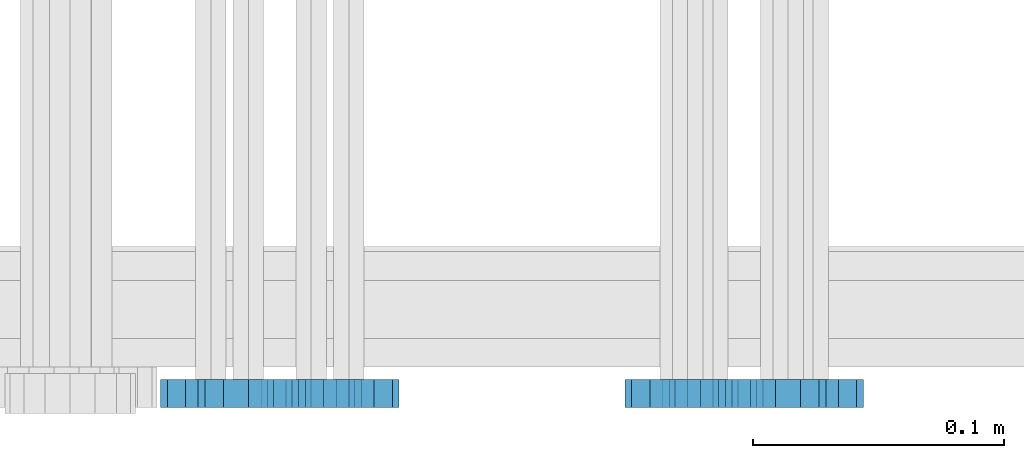
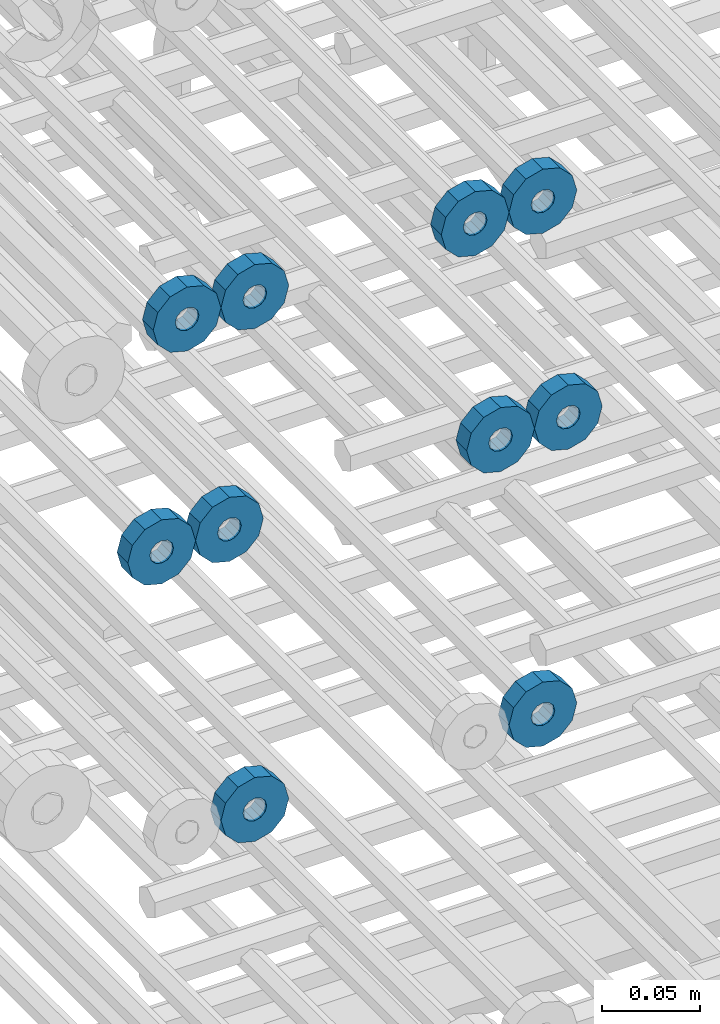
# One storey, part 159 of 177: 10 beams.
"""IFC2X3 building model written with IfcOpenShell, lengths in millimetres."""

from ifc_helpers import new_model, si_unit, frame, origin_with_axes, place, context, subcontext, project, spatial, faceted_brep, material, type_object, element, save


model = new_model("IFC2X3")

# Units and contexts
model_context_1 = context("Model", 3, precision=1e-05, world=origin_with_axes())
model_context_2 = context("Model", 3, precision=1e-05, world=origin_with_axes())
body_context = subcontext(model_context_2, "Body", "Model", "MODEL_VIEW")
ifc_project = project(units=[si_unit("LENGTHUNIT", "METRE", prefix="MILLI"), si_unit("AREAUNIT", "SQUARE_METRE"), si_unit("VOLUMEUNIT", "CUBIC_METRE"), si_unit("MASSUNIT", "GRAM", prefix="KILO"), si_unit("TIMEUNIT", "SECOND"), si_unit("PLANEANGLEUNIT", "RADIAN"), si_unit("SOLIDANGLEUNIT", "STERADIAN"), si_unit("THERMODYNAMICTEMPERATUREUNIT", "DEGREE_CELSIUS"), si_unit("LUMINOUSINTENSITYUNIT", "LUMEN")], contexts=[model_context_1])

# Site, building, storey
site_placement = place(None, origin_with_axes())
site = spatial("IfcSite", under=ifc_project, at=site_placement, CompositionType="ELEMENT")
building_placement = place(site_placement, origin_with_axes())
building = spatial("IfcBuilding", under=site, at=building_placement, Name="Undefined", CompositionType="ELEMENT")
storey_placement = place(building_placement, origin_with_axes())
storey = spatial("IfcBuildingStorey", under=building, at=storey_placement, Name="Undefined", CompositionType="ELEMENT", Elevation=0.0)

# Beams
ifc_material = material(Name="STEEL/Steel_Undefined")
beam_type = type_object("IfcBeamType", PredefinedType="NOTDEFINED")
beam_1_placement = place(storey_placement, frame((2035816.99847313, 6205070.98588033, 21144.9868114202), z_axis=(0.0, 0.0, -1.0), x_axis=(0.0, -1.0, 0.0)))
element("IfcBeam", 1, at=beam_1_placement, inside=storey, type_object=beam_type, material=ifc_material, context=body_context, shape_type="Brep", body=[
    faceted_brep([(-3.63797880709171e-12, -7.0, -2.3283064365387e-10), (-8.62348444298797e-13, -6.06217782649107, 3.5), (10.9999999999964, -6.06217782665044, 3.49999999976717), (10.9999999999964, -7.0, -2.3283064365387e-10), (-3.63797880709171e-12, -3.5, 6.06217782618478), (11.0, -3.5, 6.06217782618478), (-1.72469688859759e-12, 0.0, 7.0), (11.0, 0.0, 6.99999999976717), (-3.63797880709171e-12, 3.5, 6.06217782618478), (11.0, 3.5, 6.06217782618478), (-8.62348444298795e-13, 6.06217782649107, 3.5), (10.9999999999964, 6.06217782665044, 3.49999999976717), (-3.63797880709171e-12, 7.0, -2.3283064365387e-10), (10.9999999999964, 7.0, -2.3283064365387e-10), (8.62348444298797e-13, 6.06217782649107, -3.5), (10.9999999999964, 6.06217782665044, -3.50000000023283), (-3.63797880709171e-12, 3.5, -6.06217782665044), (10.9999999999964, 3.5, -6.06217782665044), (1.72469688859759e-12, -2.72004641033163e-15, -7.0), (10.9999999999964, 0.0, -7.00000000023283), (-3.63797880709171e-12, -3.5, -6.06217782665044), (10.9999999999964, -3.5, -6.06217782665044), (8.62348444298796e-13, -6.06217782649107, -3.5), (10.9999999999964, -6.06217782665044, -3.50000000023283), (0.0, -20.0000000009313, 0.0), (0.0, -17.320508075878, -10.0), (10.9999999999964, -17.320508075878, -10.0000000002328), (10.9999999999964, -20.0, -2.3283064365387e-10), (0.0, -10.0000000009313, -17.3205080756452), (11.0, -10.0, -17.320508075878), (0.0, -1.86264514923096e-09, -19.9999999998836), (10.9999999999964, 0.0, -20.0000000002328), (0.0, 9.99999999906868, -17.3205080755288), (11.0, 10.0, -17.320508075878), (0.0, 17.320508075878, -10.0), (10.9999999999964, 17.320508075878, -10.0000000002328), (0.0, 19.9999999990687, 0.0), (10.9999999999964, 20.0, -2.3283064365387e-10), (0.0, 17.3205080740154, 10.0), (11.0, 17.320508075878, 9.99999999976717), (0.0, 9.99999999906868, 17.3205080757616), (10.9999999999964, 10.0, 17.3205080754124), (0.0, 0.0, 20.0000000001164), (10.9999999999964, 0.0, 19.9999999997672), (0.0, -10.0000000009313, 17.3205080757616), (10.9999999999964, -10.0, 17.3205080754124), (0.0, -17.3205080777407, 10.0000000001164), (11.0, -17.320508075878, 9.99999999976717)], [[[0, 1, 2, 3]], [[1, 4, 5, 2]], [[4, 6, 7, 5]], [[6, 8, 9, 7]], [[8, 10, 11, 9]], [[10, 12, 13, 11]], [[12, 14, 15, 13]], [[14, 16, 17, 15]], [[16, 18, 19, 17]], [[18, 20, 21, 19]], [[20, 22, 23, 21]], [[22, 0, 3, 23]], [[24, 25, 26, 27]], [[25, 28, 29, 26]], [[28, 30, 31, 29]], [[30, 32, 33, 31]], [[32, 34, 35, 33]], [[34, 36, 37, 35]], [[36, 38, 39, 37]], [[38, 40, 41, 39]], [[40, 42, 43, 41]], [[42, 44, 45, 43]], [[44, 46, 47, 45]], [[46, 24, 27, 47]], [[29, 31, 33, 35, 37, 39, 41, 43, 45, 47, 27, 26], [5, 7, 9, 11, 13, 15, 17, 19, 21, 23, 3, 2]], [[46, 44, 42, 40, 38, 36, 34, 32, 30, 28, 25, 24], [22, 20, 18, 16, 14, 12, 10, 8, 6, 4, 1, 0]]]),
])
beam_2_placement = place(storey_placement, frame((2035646.99847313, 6205070.98588033, 21144.9868114254), z_axis=(0.0, 0.0, -1.0), x_axis=(0.0, -1.0, 0.0)))
element("IfcBeam", 2, at=beam_2_placement, inside=storey, type_object=beam_type, material=ifc_material, context=body_context, shape_type="Brep", body=[
    faceted_brep([(-3.63797880709171e-12, -7.0, -2.3283064365387e-10), (-8.62348444298797e-13, -6.06217782649107, 3.5), (10.9999999999964, -6.06217782665044, 3.49999999976717), (10.9999999999964, -7.0, -2.3283064365387e-10), (-3.63797880709171e-12, -3.5, 6.06217782618478), (11.0, -3.5, 6.06217782618478), (-1.72469688859759e-12, 0.0, 7.0), (11.0, 0.0, 6.99999999976717), (-3.63797880709171e-12, 3.5, 6.06217782618478), (11.0, 3.5, 6.06217782618478), (-8.62348444298795e-13, 6.06217782649107, 3.5), (10.9999999999964, 6.06217782665044, 3.49999999976717), (-3.63797880709171e-12, 7.0, -2.3283064365387e-10), (10.9999999999964, 7.0, -2.3283064365387e-10), (8.62348444298797e-13, 6.06217782649107, -3.5), (10.9999999999964, 6.06217782665044, -3.50000000023283), (-3.63797880709171e-12, 3.5, -6.06217782665044), (10.9999999999964, 3.5, -6.06217782665044), (1.72469688859759e-12, -2.72004641033163e-15, -7.0), (10.9999999999964, 0.0, -7.00000000023283), (-3.63797880709171e-12, -3.5, -6.06217782665044), (10.9999999999964, -3.5, -6.06217782665044), (8.62348444298796e-13, -6.06217782649107, -3.5), (10.9999999999964, -6.06217782665044, -3.50000000023283), (0.0, -20.0000000009313, 0.0), (0.0, -17.320508075878, -10.0), (10.9999999999964, -17.320508075878, -10.0000000002328), (10.9999999999964, -20.0, -2.3283064365387e-10), (0.0, -10.0000000009313, -17.3205080756452), (11.0, -10.0, -17.320508075878), (0.0, -1.86264514923096e-09, -19.9999999998836), (10.9999999999964, 0.0, -20.0000000002328), (0.0, 9.99999999906868, -17.3205080755288), (11.0, 10.0, -17.320508075878), (0.0, 17.320508075878, -10.0), (10.9999999999964, 17.320508075878, -10.0000000002328), (0.0, 19.9999999990687, 0.0), (10.9999999999964, 20.0, -2.3283064365387e-10), (0.0, 17.3205080740154, 10.0), (11.0, 17.320508075878, 9.99999999976717), (0.0, 9.99999999906868, 17.3205080757616), (10.9999999999964, 10.0, 17.3205080754124), (0.0, 0.0, 20.0000000001164), (10.9999999999964, 0.0, 19.9999999997672), (0.0, -10.0000000009313, 17.3205080757616), (10.9999999999964, -10.0, 17.3205080754124), (0.0, -17.3205080777407, 10.0000000001164), (11.0, -17.320508075878, 9.99999999976717)], [[[0, 1, 2, 3]], [[1, 4, 5, 2]], [[4, 6, 7, 5]], [[6, 8, 9, 7]], [[8, 10, 11, 9]], [[10, 12, 13, 11]], [[12, 14, 15, 13]], [[14, 16, 17, 15]], [[16, 18, 19, 17]], [[18, 20, 21, 19]], [[20, 22, 23, 21]], [[22, 0, 3, 23]], [[24, 25, 26, 27]], [[25, 28, 29, 26]], [[28, 30, 31, 29]], [[30, 32, 33, 31]], [[32, 34, 35, 33]], [[34, 36, 37, 35]], [[36, 38, 39, 37]], [[38, 40, 41, 39]], [[40, 42, 43, 41]], [[42, 44, 45, 43]], [[44, 46, 47, 45]], [[46, 24, 27, 47]], [[29, 31, 33, 35, 37, 39, 41, 43, 45, 47, 27, 26], [5, 7, 9, 11, 13, 15, 17, 19, 21, 23, 3, 2]], [[46, 44, 42, 40, 38, 36, 34, 32, 30, 28, 25, 24], [22, 20, 18, 16, 14, 12, 10, 8, 6, 4, 1, 0]]]),
])
beam_3_placement = place(storey_placement, frame((2035776.99847313, 6205070.98588033, 21144.9868114202), z_axis=(0.0, 0.0, -1.0), x_axis=(0.0, -1.0, 0.0)))
element("IfcBeam", 3, at=beam_3_placement, inside=storey, type_object=beam_type, material=ifc_material, context=body_context, shape_type="Brep", body=[
    faceted_brep([(-3.63797880709171e-12, -7.0, -2.3283064365387e-10), (-8.62348444298797e-13, -6.06217782649107, 3.5), (10.9999999999964, -6.06217782665044, 3.49999999976717), (10.9999999999964, -7.0, -2.3283064365387e-10), (-3.63797880709171e-12, -3.5, 6.06217782618478), (11.0, -3.5, 6.06217782618478), (-1.72469688859759e-12, 0.0, 7.0), (11.0, 0.0, 6.99999999976717), (-3.63797880709171e-12, 3.5, 6.06217782618478), (11.0, 3.5, 6.06217782618478), (-8.62348444298795e-13, 6.06217782649107, 3.5), (10.9999999999964, 6.06217782665044, 3.49999999976717), (-3.63797880709171e-12, 7.0, -2.3283064365387e-10), (10.9999999999964, 7.0, -2.3283064365387e-10), (8.62348444298797e-13, 6.06217782649107, -3.5), (10.9999999999964, 6.06217782665044, -3.50000000023283), (-3.63797880709171e-12, 3.5, -6.06217782665044), (10.9999999999964, 3.5, -6.06217782665044), (1.72469688859759e-12, -2.72004641033163e-15, -7.0), (10.9999999999964, 0.0, -7.00000000023283), (-3.63797880709171e-12, -3.5, -6.06217782665044), (10.9999999999964, -3.5, -6.06217782665044), (8.62348444298796e-13, -6.06217782649107, -3.5), (10.9999999999964, -6.06217782665044, -3.50000000023283), (0.0, -20.0000000009313, 0.0), (0.0, -17.320508075878, -10.0), (10.9999999999964, -17.320508075878, -10.0000000002328), (10.9999999999964, -20.0, -2.3283064365387e-10), (0.0, -10.0000000009313, -17.3205080756452), (11.0, -10.0, -17.320508075878), (0.0, -1.86264514923096e-09, -19.9999999998836), (10.9999999999964, 0.0, -20.0000000002328), (0.0, 9.99999999906868, -17.3205080755288), (11.0, 10.0, -17.320508075878), (0.0, 17.320508075878, -10.0), (10.9999999999964, 17.320508075878, -10.0000000002328), (0.0, 19.9999999990687, 0.0), (10.9999999999964, 20.0, -2.3283064365387e-10), (0.0, 17.3205080740154, 10.0), (11.0, 17.320508075878, 9.99999999976717), (0.0, 9.99999999906868, 17.3205080757616), (10.9999999999964, 10.0, 17.3205080754124), (0.0, 0.0, 20.0000000001164), (10.9999999999964, 0.0, 19.9999999997672), (0.0, -10.0000000009313, 17.3205080757616), (10.9999999999964, -10.0, 17.3205080754124), (0.0, -17.3205080777407, 10.0000000001164), (11.0, -17.320508075878, 9.99999999976717)], [[[0, 1, 2, 3]], [[1, 4, 5, 2]], [[4, 6, 7, 5]], [[6, 8, 9, 7]], [[8, 10, 11, 9]], [[10, 12, 13, 11]], [[12, 14, 15, 13]], [[14, 16, 17, 15]], [[16, 18, 19, 17]], [[18, 20, 21, 19]], [[20, 22, 23, 21]], [[22, 0, 3, 23]], [[24, 25, 26, 27]], [[25, 28, 29, 26]], [[28, 30, 31, 29]], [[30, 32, 33, 31]], [[32, 34, 35, 33]], [[34, 36, 37, 35]], [[36, 38, 39, 37]], [[38, 40, 41, 39]], [[40, 42, 43, 41]], [[42, 44, 45, 43]], [[44, 46, 47, 45]], [[46, 24, 27, 47]], [[29, 31, 33, 35, 37, 39, 41, 43, 45, 47, 27, 26], [5, 7, 9, 11, 13, 15, 17, 19, 21, 23, 3, 2]], [[46, 44, 42, 40, 38, 36, 34, 32, 30, 28, 25, 24], [22, 20, 18, 16, 14, 12, 10, 8, 6, 4, 1, 0]]]),
])
beam_4_placement = place(storey_placement, frame((2035606.99847313, 6205070.98588033, 21144.9868114254), z_axis=(0.0, 0.0, -1.0), x_axis=(0.0, -1.0, 0.0)))
element("IfcBeam", 4, at=beam_4_placement, inside=storey, type_object=beam_type, material=ifc_material, context=body_context, shape_type="Brep", body=[
    faceted_brep([(-3.63797880709171e-12, -7.0, -2.3283064365387e-10), (-8.62348444298797e-13, -6.06217782649107, 3.5), (10.9999999999964, -6.06217782665044, 3.49999999976717), (10.9999999999964, -7.0, -2.3283064365387e-10), (-3.63797880709171e-12, -3.5, 6.06217782618478), (11.0, -3.5, 6.06217782618478), (-1.72469688859759e-12, 0.0, 7.0), (11.0, 0.0, 6.99999999976717), (-3.63797880709171e-12, 3.5, 6.06217782618478), (11.0, 3.5, 6.06217782618478), (-8.62348444298795e-13, 6.06217782649107, 3.5), (10.9999999999964, 6.06217782665044, 3.49999999976717), (-3.63797880709171e-12, 7.0, -2.3283064365387e-10), (10.9999999999964, 7.0, -2.3283064365387e-10), (8.62348444298797e-13, 6.06217782649107, -3.5), (10.9999999999964, 6.06217782665044, -3.50000000023283), (-3.63797880709171e-12, 3.5, -6.06217782665044), (10.9999999999964, 3.5, -6.06217782665044), (1.72469688859759e-12, -2.72004641033163e-15, -7.0), (10.9999999999964, 0.0, -7.00000000023283), (-3.63797880709171e-12, -3.5, -6.06217782665044), (10.9999999999964, -3.5, -6.06217782665044), (8.62348444298796e-13, -6.06217782649107, -3.5), (10.9999999999964, -6.06217782665044, -3.50000000023283), (0.0, -20.0000000009313, 0.0), (0.0, -17.320508075878, -10.0), (10.9999999999964, -17.320508075878, -10.0000000002328), (10.9999999999964, -20.0, -2.3283064365387e-10), (0.0, -10.0000000009313, -17.3205080756452), (11.0, -10.0, -17.320508075878), (0.0, -1.86264514923096e-09, -19.9999999998836), (10.9999999999964, 0.0, -20.0000000002328), (0.0, 9.99999999906868, -17.3205080755288), (11.0, 10.0, -17.320508075878), (0.0, 17.320508075878, -10.0), (10.9999999999964, 17.320508075878, -10.0000000002328), (0.0, 19.9999999990687, 0.0), (10.9999999999964, 20.0, -2.3283064365387e-10), (0.0, 17.3205080740154, 10.0), (11.0, 17.320508075878, 9.99999999976717), (0.0, 9.99999999906868, 17.3205080757616), (10.9999999999964, 10.0, 17.3205080754124), (0.0, 0.0, 20.0000000001164), (10.9999999999964, 0.0, 19.9999999997672), (0.0, -10.0000000009313, 17.3205080757616), (10.9999999999964, -10.0, 17.3205080754124), (0.0, -17.3205080777407, 10.0000000001164), (11.0, -17.320508075878, 9.99999999976717)], [[[0, 1, 2, 3]], [[1, 4, 5, 2]], [[4, 6, 7, 5]], [[6, 8, 9, 7]], [[8, 10, 11, 9]], [[10, 12, 13, 11]], [[12, 14, 15, 13]], [[14, 16, 17, 15]], [[16, 18, 19, 17]], [[18, 20, 21, 19]], [[20, 22, 23, 21]], [[22, 0, 3, 23]], [[24, 25, 26, 27]], [[25, 28, 29, 26]], [[28, 30, 31, 29]], [[30, 32, 33, 31]], [[32, 34, 35, 33]], [[34, 36, 37, 35]], [[36, 38, 39, 37]], [[38, 40, 41, 39]], [[40, 42, 43, 41]], [[42, 44, 45, 43]], [[44, 46, 47, 45]], [[46, 24, 27, 47]], [[29, 31, 33, 35, 37, 39, 41, 43, 45, 47, 27, 26], [5, 7, 9, 11, 13, 15, 17, 19, 21, 23, 3, 2]], [[46, 44, 42, 40, 38, 36, 34, 32, 30, 28, 25, 24], [22, 20, 18, 16, 14, 12, 10, 8, 6, 4, 1, 0]]]),
])
beam_5_placement = place(storey_placement, frame((2035831.99847313, 6205070.98588033, 21004.9868114202), z_axis=(0.0, 0.0, -1.0), x_axis=(0.0, -1.0, 0.0)))
element("IfcBeam", 5, at=beam_5_placement, inside=storey, type_object=beam_type, material=ifc_material, context=body_context, shape_type="Brep", body=[
    faceted_brep([(-3.63797880709171e-12, -7.0, -2.3283064365387e-10), (-8.62348444298797e-13, -6.06217782649107, 3.5), (10.9999999999964, -6.06217782665044, 3.49999999976717), (10.9999999999964, -7.0, -2.3283064365387e-10), (-3.63797880709171e-12, -3.5, 6.06217782618478), (11.0, -3.5, 6.06217782618478), (-1.72469688859759e-12, 0.0, 7.0), (11.0, 0.0, 6.99999999976717), (-3.63797880709171e-12, 3.5, 6.06217782618478), (11.0, 3.5, 6.06217782618478), (-8.62348444298795e-13, 6.06217782649107, 3.5), (10.9999999999964, 6.06217782665044, 3.49999999976717), (-3.63797880709171e-12, 7.0, -2.3283064365387e-10), (10.9999999999964, 7.0, -2.3283064365387e-10), (8.62348444298797e-13, 6.06217782649107, -3.5), (10.9999999999964, 6.06217782665044, -3.50000000023283), (-3.63797880709171e-12, 3.5, -6.06217782665044), (10.9999999999964, 3.5, -6.06217782665044), (1.72469688859759e-12, -2.72004641033163e-15, -7.0), (10.9999999999964, 0.0, -7.00000000023283), (-3.63797880709171e-12, -3.5, -6.06217782665044), (10.9999999999964, -3.5, -6.06217782665044), (8.62348444298796e-13, -6.06217782649107, -3.5), (10.9999999999964, -6.06217782665044, -3.50000000023283), (0.0, -20.0000000009313, 0.0), (0.0, -17.320508075878, -10.0), (10.9999999999964, -17.320508075878, -10.0000000002328), (10.9999999999964, -20.0, -2.3283064365387e-10), (0.0, -10.0000000009313, -17.3205080756452), (11.0, -10.0, -17.320508075878), (0.0, -1.86264514923096e-09, -19.9999999998836), (10.9999999999964, 0.0, -20.0000000002328), (0.0, 9.99999999906868, -17.3205080755288), (11.0, 10.0, -17.320508075878), (0.0, 17.320508075878, -10.0), (10.9999999999964, 17.320508075878, -10.0000000002328), (0.0, 19.9999999990687, 0.0), (10.9999999999964, 20.0, -2.3283064365387e-10), (0.0, 17.3205080740154, 10.0), (11.0, 17.320508075878, 9.99999999976717), (0.0, 9.99999999906868, 17.3205080757616), (10.9999999999964, 10.0, 17.3205080754124), (0.0, 0.0, 20.0000000001164), (10.9999999999964, 0.0, 19.9999999997672), (0.0, -10.0000000009313, 17.3205080757616), (10.9999999999964, -10.0, 17.3205080754124), (0.0, -17.3205080777407, 10.0000000001164), (11.0, -17.320508075878, 9.99999999976717)], [[[0, 1, 2, 3]], [[1, 4, 5, 2]], [[4, 6, 7, 5]], [[6, 8, 9, 7]], [[8, 10, 11, 9]], [[10, 12, 13, 11]], [[12, 14, 15, 13]], [[14, 16, 17, 15]], [[16, 18, 19, 17]], [[18, 20, 21, 19]], [[20, 22, 23, 21]], [[22, 0, 3, 23]], [[24, 25, 26, 27]], [[25, 28, 29, 26]], [[28, 30, 31, 29]], [[30, 32, 33, 31]], [[32, 34, 35, 33]], [[34, 36, 37, 35]], [[36, 38, 39, 37]], [[38, 40, 41, 39]], [[40, 42, 43, 41]], [[42, 44, 45, 43]], [[44, 46, 47, 45]], [[46, 24, 27, 47]], [[29, 31, 33, 35, 37, 39, 41, 43, 45, 47, 27, 26], [5, 7, 9, 11, 13, 15, 17, 19, 21, 23, 3, 2]], [[46, 44, 42, 40, 38, 36, 34, 32, 30, 28, 25, 24], [22, 20, 18, 16, 14, 12, 10, 8, 6, 4, 1, 0]]]),
])
beam_6_placement = place(storey_placement, frame((2035631.99847313, 6205070.98588033, 21004.9868114202), z_axis=(0.0, 0.0, -1.0), x_axis=(0.0, -1.0, 0.0)))
element("IfcBeam", 6, at=beam_6_placement, inside=storey, type_object=beam_type, material=ifc_material, context=body_context, shape_type="Brep", body=[
    faceted_brep([(-3.63797880709171e-12, -7.0, -2.3283064365387e-10), (-8.62348444298797e-13, -6.06217782649107, 3.5), (10.9999999999964, -6.06217782665044, 3.49999999976717), (10.9999999999964, -7.0, -2.3283064365387e-10), (-3.63797880709171e-12, -3.5, 6.06217782618478), (11.0, -3.5, 6.06217782618478), (-1.72469688859759e-12, 0.0, 7.0), (11.0, 0.0, 6.99999999976717), (-3.63797880709171e-12, 3.5, 6.06217782618478), (11.0, 3.5, 6.06217782618478), (-8.62348444298795e-13, 6.06217782649107, 3.5), (10.9999999999964, 6.06217782665044, 3.49999999976717), (-3.63797880709171e-12, 7.0, -2.3283064365387e-10), (10.9999999999964, 7.0, -2.3283064365387e-10), (8.62348444298797e-13, 6.06217782649107, -3.5), (10.9999999999964, 6.06217782665044, -3.50000000023283), (-3.63797880709171e-12, 3.5, -6.06217782665044), (10.9999999999964, 3.5, -6.06217782665044), (1.72469688859759e-12, -2.72004641033163e-15, -7.0), (10.9999999999964, 0.0, -7.00000000023283), (-3.63797880709171e-12, -3.5, -6.06217782665044), (10.9999999999964, -3.5, -6.06217782665044), (8.62348444298796e-13, -6.06217782649107, -3.5), (10.9999999999964, -6.06217782665044, -3.50000000023283), (0.0, -20.0000000009313, 0.0), (0.0, -17.320508075878, -10.0), (10.9999999999964, -17.320508075878, -10.0000000002328), (10.9999999999964, -20.0, -2.3283064365387e-10), (0.0, -10.0000000009313, -17.3205080756452), (11.0, -10.0, -17.320508075878), (0.0, -1.86264514923096e-09, -19.9999999998836), (10.9999999999964, 0.0, -20.0000000002328), (0.0, 9.99999999906868, -17.3205080755288), (11.0, 10.0, -17.320508075878), (0.0, 17.320508075878, -10.0), (10.9999999999964, 17.320508075878, -10.0000000002328), (0.0, 19.9999999990687, 0.0), (10.9999999999964, 20.0, -2.3283064365387e-10), (0.0, 17.3205080740154, 10.0), (11.0, 17.320508075878, 9.99999999976717), (0.0, 9.99999999906868, 17.3205080757616), (10.9999999999964, 10.0, 17.3205080754124), (0.0, 0.0, 20.0000000001164), (10.9999999999964, 0.0, 19.9999999997672), (0.0, -10.0000000009313, 17.3205080757616), (10.9999999999964, -10.0, 17.3205080754124), (0.0, -17.3205080777407, 10.0000000001164), (11.0, -17.320508075878, 9.99999999976717)], [[[0, 1, 2, 3]], [[1, 4, 5, 2]], [[4, 6, 7, 5]], [[6, 8, 9, 7]], [[8, 10, 11, 9]], [[10, 12, 13, 11]], [[12, 14, 15, 13]], [[14, 16, 17, 15]], [[16, 18, 19, 17]], [[18, 20, 21, 19]], [[20, 22, 23, 21]], [[22, 0, 3, 23]], [[24, 25, 26, 27]], [[25, 28, 29, 26]], [[28, 30, 31, 29]], [[30, 32, 33, 31]], [[32, 34, 35, 33]], [[34, 36, 37, 35]], [[36, 38, 39, 37]], [[38, 40, 41, 39]], [[40, 42, 43, 41]], [[42, 44, 45, 43]], [[44, 46, 47, 45]], [[46, 24, 27, 47]], [[29, 31, 33, 35, 37, 39, 41, 43, 45, 47, 27, 26], [5, 7, 9, 11, 13, 15, 17, 19, 21, 23, 3, 2]], [[46, 44, 42, 40, 38, 36, 34, 32, 30, 28, 25, 24], [22, 20, 18, 16, 14, 12, 10, 8, 6, 4, 1, 0]]]),
])
beam_7_placement = place(storey_placement, frame((2035791.99847313, 6205070.98588033, 21004.9868114202), z_axis=(0.0, 0.0, -1.0), x_axis=(0.0, -1.0, 0.0)))
element("IfcBeam", 7, at=beam_7_placement, inside=storey, type_object=beam_type, material=ifc_material, context=body_context, shape_type="Brep", body=[
    faceted_brep([(-3.63797880709171e-12, -7.0, -2.3283064365387e-10), (-8.62348444298797e-13, -6.06217782649107, 3.5), (10.9999999999964, -6.06217782665044, 3.49999999976717), (10.9999999999964, -7.0, -2.3283064365387e-10), (-3.63797880709171e-12, -3.5, 6.06217782618478), (11.0, -3.5, 6.06217782618478), (-1.72469688859759e-12, 0.0, 7.0), (11.0, 0.0, 6.99999999976717), (-3.63797880709171e-12, 3.5, 6.06217782618478), (11.0, 3.5, 6.06217782618478), (-8.62348444298795e-13, 6.06217782649107, 3.5), (10.9999999999964, 6.06217782665044, 3.49999999976717), (-3.63797880709171e-12, 7.0, -2.3283064365387e-10), (10.9999999999964, 7.0, -2.3283064365387e-10), (8.62348444298797e-13, 6.06217782649107, -3.5), (10.9999999999964, 6.06217782665044, -3.50000000023283), (-3.63797880709171e-12, 3.5, -6.06217782665044), (10.9999999999964, 3.5, -6.06217782665044), (1.72469688859759e-12, -2.72004641033163e-15, -7.0), (10.9999999999964, 0.0, -7.00000000023283), (-3.63797880709171e-12, -3.5, -6.06217782665044), (10.9999999999964, -3.5, -6.06217782665044), (8.62348444298796e-13, -6.06217782649107, -3.5), (10.9999999999964, -6.06217782665044, -3.50000000023283), (0.0, -20.0000000009313, 0.0), (0.0, -17.320508075878, -10.0), (10.9999999999964, -17.320508075878, -10.0000000002328), (10.9999999999964, -20.0, -2.3283064365387e-10), (0.0, -10.0000000009313, -17.3205080756452), (11.0, -10.0, -17.320508075878), (0.0, -1.86264514923096e-09, -19.9999999998836), (10.9999999999964, 0.0, -20.0000000002328), (0.0, 9.99999999906868, -17.3205080755288), (11.0, 10.0, -17.320508075878), (0.0, 17.320508075878, -10.0), (10.9999999999964, 17.320508075878, -10.0000000002328), (0.0, 19.9999999990687, 0.0), (10.9999999999964, 20.0, -2.3283064365387e-10), (0.0, 17.3205080740154, 10.0), (11.0, 17.320508075878, 9.99999999976717), (0.0, 9.99999999906868, 17.3205080757616), (10.9999999999964, 10.0, 17.3205080754124), (0.0, 0.0, 20.0000000001164), (10.9999999999964, 0.0, 19.9999999997672), (0.0, -10.0000000009313, 17.3205080757616), (10.9999999999964, -10.0, 17.3205080754124), (0.0, -17.3205080777407, 10.0000000001164), (11.0, -17.320508075878, 9.99999999976717)], [[[0, 1, 2, 3]], [[1, 4, 5, 2]], [[4, 6, 7, 5]], [[6, 8, 9, 7]], [[8, 10, 11, 9]], [[10, 12, 13, 11]], [[12, 14, 15, 13]], [[14, 16, 17, 15]], [[16, 18, 19, 17]], [[18, 20, 21, 19]], [[20, 22, 23, 21]], [[22, 0, 3, 23]], [[24, 25, 26, 27]], [[25, 28, 29, 26]], [[28, 30, 31, 29]], [[30, 32, 33, 31]], [[32, 34, 35, 33]], [[34, 36, 37, 35]], [[36, 38, 39, 37]], [[38, 40, 41, 39]], [[40, 42, 43, 41]], [[42, 44, 45, 43]], [[44, 46, 47, 45]], [[46, 24, 27, 47]], [[29, 31, 33, 35, 37, 39, 41, 43, 45, 47, 27, 26], [5, 7, 9, 11, 13, 15, 17, 19, 21, 23, 3, 2]], [[46, 44, 42, 40, 38, 36, 34, 32, 30, 28, 25, 24], [22, 20, 18, 16, 14, 12, 10, 8, 6, 4, 1, 0]]]),
])
beam_8_placement = place(storey_placement, frame((2035591.99847313, 6205070.98588033, 21004.9868114202), z_axis=(0.0, 0.0, -1.0), x_axis=(0.0, -1.0, 0.0)))
element("IfcBeam", 8, at=beam_8_placement, inside=storey, type_object=beam_type, material=ifc_material, context=body_context, shape_type="Brep", body=[
    faceted_brep([(-3.63797880709171e-12, -7.0, -2.3283064365387e-10), (-8.62348444298797e-13, -6.06217782649107, 3.5), (10.9999999999964, -6.06217782665044, 3.49999999976717), (10.9999999999964, -7.0, -2.3283064365387e-10), (-3.63797880709171e-12, -3.5, 6.06217782618478), (11.0, -3.5, 6.06217782618478), (-1.72469688859759e-12, 0.0, 7.0), (11.0, 0.0, 6.99999999976717), (-3.63797880709171e-12, 3.5, 6.06217782618478), (11.0, 3.5, 6.06217782618478), (-8.62348444298795e-13, 6.06217782649107, 3.5), (10.9999999999964, 6.06217782665044, 3.49999999976717), (-3.63797880709171e-12, 7.0, -2.3283064365387e-10), (10.9999999999964, 7.0, -2.3283064365387e-10), (8.62348444298797e-13, 6.06217782649107, -3.5), (10.9999999999964, 6.06217782665044, -3.50000000023283), (-3.63797880709171e-12, 3.5, -6.06217782665044), (10.9999999999964, 3.5, -6.06217782665044), (1.72469688859759e-12, -2.72004641033163e-15, -7.0), (10.9999999999964, 0.0, -7.00000000023283), (-3.63797880709171e-12, -3.5, -6.06217782665044), (10.9999999999964, -3.5, -6.06217782665044), (8.62348444298796e-13, -6.06217782649107, -3.5), (10.9999999999964, -6.06217782665044, -3.50000000023283), (0.0, -20.0000000009313, 0.0), (0.0, -17.320508075878, -10.0), (10.9999999999964, -17.320508075878, -10.0000000002328), (10.9999999999964, -20.0, -2.3283064365387e-10), (0.0, -10.0000000009313, -17.3205080756452), (11.0, -10.0, -17.320508075878), (0.0, -1.86264514923096e-09, -19.9999999998836), (10.9999999999964, 0.0, -20.0000000002328), (0.0, 9.99999999906868, -17.3205080755288), (11.0, 10.0, -17.320508075878), (0.0, 17.320508075878, -10.0), (10.9999999999964, 17.320508075878, -10.0000000002328), (0.0, 19.9999999990687, 0.0), (10.9999999999964, 20.0, -2.3283064365387e-10), (0.0, 17.3205080740154, 10.0), (11.0, 17.320508075878, 9.99999999976717), (0.0, 9.99999999906868, 17.3205080757616), (10.9999999999964, 10.0, 17.3205080754124), (0.0, 0.0, 20.0000000001164), (10.9999999999964, 0.0, 19.9999999997672), (0.0, -10.0000000009313, 17.3205080757616), (10.9999999999964, -10.0, 17.3205080754124), (0.0, -17.3205080777407, 10.0000000001164), (11.0, -17.320508075878, 9.99999999976717)], [[[0, 1, 2, 3]], [[1, 4, 5, 2]], [[4, 6, 7, 5]], [[6, 8, 9, 7]], [[8, 10, 11, 9]], [[10, 12, 13, 11]], [[12, 14, 15, 13]], [[14, 16, 17, 15]], [[16, 18, 19, 17]], [[18, 20, 21, 19]], [[20, 22, 23, 21]], [[22, 0, 3, 23]], [[24, 25, 26, 27]], [[25, 28, 29, 26]], [[28, 30, 31, 29]], [[30, 32, 33, 31]], [[32, 34, 35, 33]], [[34, 36, 37, 35]], [[36, 38, 39, 37]], [[38, 40, 41, 39]], [[40, 42, 43, 41]], [[42, 44, 45, 43]], [[44, 46, 47, 45]], [[46, 24, 27, 47]], [[29, 31, 33, 35, 37, 39, 41, 43, 45, 47, 27, 26], [5, 7, 9, 11, 13, 15, 17, 19, 21, 23, 3, 2]], [[46, 44, 42, 40, 38, 36, 34, 32, 30, 28, 25, 24], [22, 20, 18, 16, 14, 12, 10, 8, 6, 4, 1, 0]]]),
])
beam_9_placement = place(storey_placement, frame((2035816.99847313, 6205070.98588033, 20824.9868114202), z_axis=(0.0, 0.0, -1.0), x_axis=(0.0, -1.0, 0.0)))
element("IfcBeam", 9, at=beam_9_placement, inside=storey, type_object=beam_type, material=ifc_material, context=body_context, shape_type="Brep", body=[
    faceted_brep([(-3.63797880709171e-12, -7.0, -2.3283064365387e-10), (-8.62348444298797e-13, -6.06217782649107, 3.5), (10.9999999999964, -6.06217782665044, 3.49999999976717), (10.9999999999964, -7.0, -2.3283064365387e-10), (-3.63797880709171e-12, -3.5, 6.06217782618478), (11.0, -3.5, 6.06217782618478), (-1.72469688859759e-12, 0.0, 7.0), (11.0, 0.0, 6.99999999976717), (-3.63797880709171e-12, 3.5, 6.06217782618478), (11.0, 3.5, 6.06217782618478), (-8.62348444298795e-13, 6.06217782649107, 3.5), (10.9999999999964, 6.06217782665044, 3.49999999976717), (-3.63797880709171e-12, 7.0, -2.3283064365387e-10), (10.9999999999964, 7.0, -2.3283064365387e-10), (8.62348444298797e-13, 6.06217782649107, -3.5), (10.9999999999964, 6.06217782665044, -3.50000000023283), (-3.63797880709171e-12, 3.5, -6.06217782665044), (10.9999999999964, 3.5, -6.06217782665044), (1.72469688859759e-12, -2.72004641033163e-15, -7.0), (10.9999999999964, 0.0, -7.00000000023283), (-3.63797880709171e-12, -3.5, -6.06217782665044), (10.9999999999964, -3.5, -6.06217782665044), (8.62348444298796e-13, -6.06217782649107, -3.5), (10.9999999999964, -6.06217782665044, -3.50000000023283), (0.0, -20.0000000009313, 0.0), (0.0, -17.320508075878, -10.0), (10.9999999999964, -17.320508075878, -10.0000000002328), (10.9999999999964, -20.0, -2.3283064365387e-10), (0.0, -10.0000000009313, -17.3205080756452), (11.0, -10.0, -17.320508075878), (0.0, -1.86264514923096e-09, -19.9999999998836), (10.9999999999964, 0.0, -20.0000000002328), (0.0, 9.99999999906868, -17.3205080755288), (11.0, 10.0, -17.320508075878), (0.0, 17.320508075878, -10.0), (10.9999999999964, 17.320508075878, -10.0000000002328), (0.0, 19.9999999990687, 0.0), (10.9999999999964, 20.0, -2.3283064365387e-10), (0.0, 17.3205080740154, 10.0), (11.0, 17.320508075878, 9.99999999976717), (0.0, 9.99999999906868, 17.3205080757616), (10.9999999999964, 10.0, 17.3205080754124), (0.0, 0.0, 20.0000000001164), (10.9999999999964, 0.0, 19.9999999997672), (0.0, -10.0000000009313, 17.3205080757616), (10.9999999999964, -10.0, 17.3205080754124), (0.0, -17.3205080777407, 10.0000000001164), (11.0, -17.320508075878, 9.99999999976717)], [[[0, 1, 2, 3]], [[1, 4, 5, 2]], [[4, 6, 7, 5]], [[6, 8, 9, 7]], [[8, 10, 11, 9]], [[10, 12, 13, 11]], [[12, 14, 15, 13]], [[14, 16, 17, 15]], [[16, 18, 19, 17]], [[18, 20, 21, 19]], [[20, 22, 23, 21]], [[22, 0, 3, 23]], [[24, 25, 26, 27]], [[25, 28, 29, 26]], [[28, 30, 31, 29]], [[30, 32, 33, 31]], [[32, 34, 35, 33]], [[34, 36, 37, 35]], [[36, 38, 39, 37]], [[38, 40, 41, 39]], [[40, 42, 43, 41]], [[42, 44, 45, 43]], [[44, 46, 47, 45]], [[46, 24, 27, 47]], [[29, 31, 33, 35, 37, 39, 41, 43, 45, 47, 27, 26], [5, 7, 9, 11, 13, 15, 17, 19, 21, 23, 3, 2]], [[46, 44, 42, 40, 38, 36, 34, 32, 30, 28, 25, 24], [22, 20, 18, 16, 14, 12, 10, 8, 6, 4, 1, 0]]]),
])
beam_10_placement = place(storey_placement, frame((2035646.99847313, 6205070.98588033, 20824.9868114254), z_axis=(0.0, 0.0, -1.0), x_axis=(0.0, -1.0, 0.0)))
element("IfcBeam", 10, at=beam_10_placement, inside=storey, type_object=beam_type, material=ifc_material, context=body_context, shape_type="Brep", body=[
    faceted_brep([(-3.63797880709171e-12, -7.0, -2.3283064365387e-10), (-8.62348444298797e-13, -6.06217782649107, 3.5), (10.9999999999964, -6.06217782665044, 3.49999999976717), (10.9999999999964, -7.0, -2.3283064365387e-10), (-3.63797880709171e-12, -3.5, 6.06217782618478), (11.0, -3.5, 6.06217782618478), (-1.72469688859759e-12, 0.0, 7.0), (11.0, 0.0, 6.99999999976717), (-3.63797880709171e-12, 3.5, 6.06217782618478), (11.0, 3.5, 6.06217782618478), (-8.62348444298795e-13, 6.06217782649107, 3.5), (10.9999999999964, 6.06217782665044, 3.49999999976717), (-3.63797880709171e-12, 7.0, -2.3283064365387e-10), (10.9999999999964, 7.0, -2.3283064365387e-10), (8.62348444298797e-13, 6.06217782649107, -3.5), (10.9999999999964, 6.06217782665044, -3.50000000023283), (-3.63797880709171e-12, 3.5, -6.06217782665044), (10.9999999999964, 3.5, -6.06217782665044), (1.72469688859759e-12, -2.72004641033163e-15, -7.0), (10.9999999999964, 0.0, -7.00000000023283), (-3.63797880709171e-12, -3.5, -6.06217782665044), (10.9999999999964, -3.5, -6.06217782665044), (8.62348444298796e-13, -6.06217782649107, -3.5), (10.9999999999964, -6.06217782665044, -3.50000000023283), (0.0, -20.0000000009313, 0.0), (0.0, -17.320508075878, -10.0), (10.9999999999964, -17.320508075878, -10.0000000002328), (10.9999999999964, -20.0, -2.3283064365387e-10), (0.0, -10.0000000009313, -17.3205080756452), (11.0, -10.0, -17.320508075878), (0.0, -1.86264514923096e-09, -19.9999999998836), (10.9999999999964, 0.0, -20.0000000002328), (0.0, 9.99999999906868, -17.3205080755288), (11.0, 10.0, -17.320508075878), (0.0, 17.320508075878, -10.0), (10.9999999999964, 17.320508075878, -10.0000000002328), (0.0, 19.9999999990687, 0.0), (10.9999999999964, 20.0, -2.3283064365387e-10), (0.0, 17.3205080740154, 10.0), (11.0, 17.320508075878, 9.99999999976717), (0.0, 9.99999999906868, 17.3205080757616), (10.9999999999964, 10.0, 17.3205080754124), (0.0, 0.0, 20.0000000001164), (10.9999999999964, 0.0, 19.9999999997672), (0.0, -10.0000000009313, 17.3205080757616), (10.9999999999964, -10.0, 17.3205080754124), (0.0, -17.3205080777407, 10.0000000001164), (11.0, -17.320508075878, 9.99999999976717)], [[[0, 1, 2, 3]], [[1, 4, 5, 2]], [[4, 6, 7, 5]], [[6, 8, 9, 7]], [[8, 10, 11, 9]], [[10, 12, 13, 11]], [[12, 14, 15, 13]], [[14, 16, 17, 15]], [[16, 18, 19, 17]], [[18, 20, 21, 19]], [[20, 22, 23, 21]], [[22, 0, 3, 23]], [[24, 25, 26, 27]], [[25, 28, 29, 26]], [[28, 30, 31, 29]], [[30, 32, 33, 31]], [[32, 34, 35, 33]], [[34, 36, 37, 35]], [[36, 38, 39, 37]], [[38, 40, 41, 39]], [[40, 42, 43, 41]], [[42, 44, 45, 43]], [[44, 46, 47, 45]], [[46, 24, 27, 47]], [[29, 31, 33, 35, 37, 39, 41, 43, 45, 47, 27, 26], [5, 7, 9, 11, 13, 15, 17, 19, 21, 23, 3, 2]], [[46, 44, 42, 40, 38, 36, 34, 32, 30, 28, 25, 24], [22, 20, 18, 16, 14, 12, 10, 8, 6, 4, 1, 0]]]),
])

save(model, "model.ifc")
